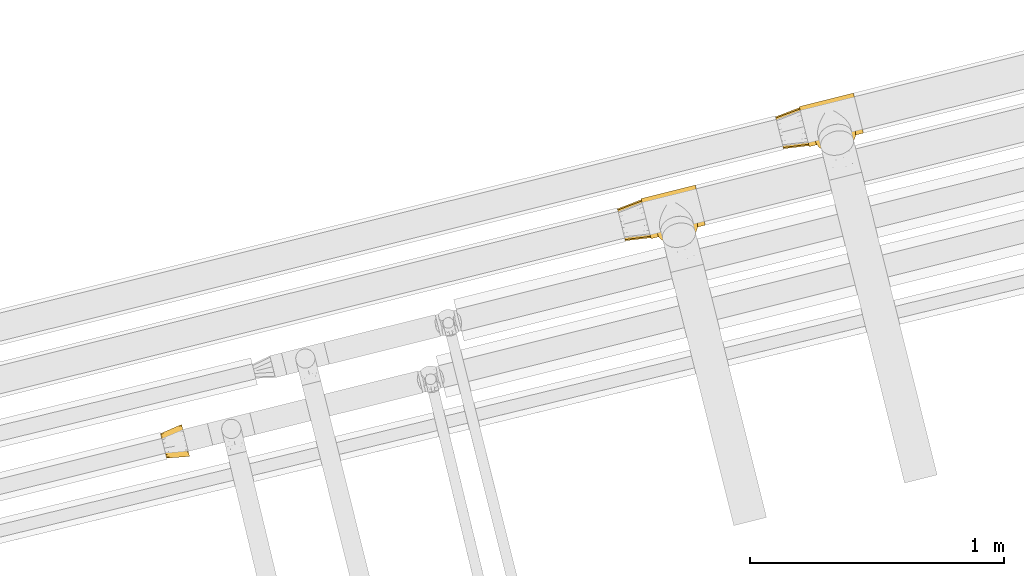
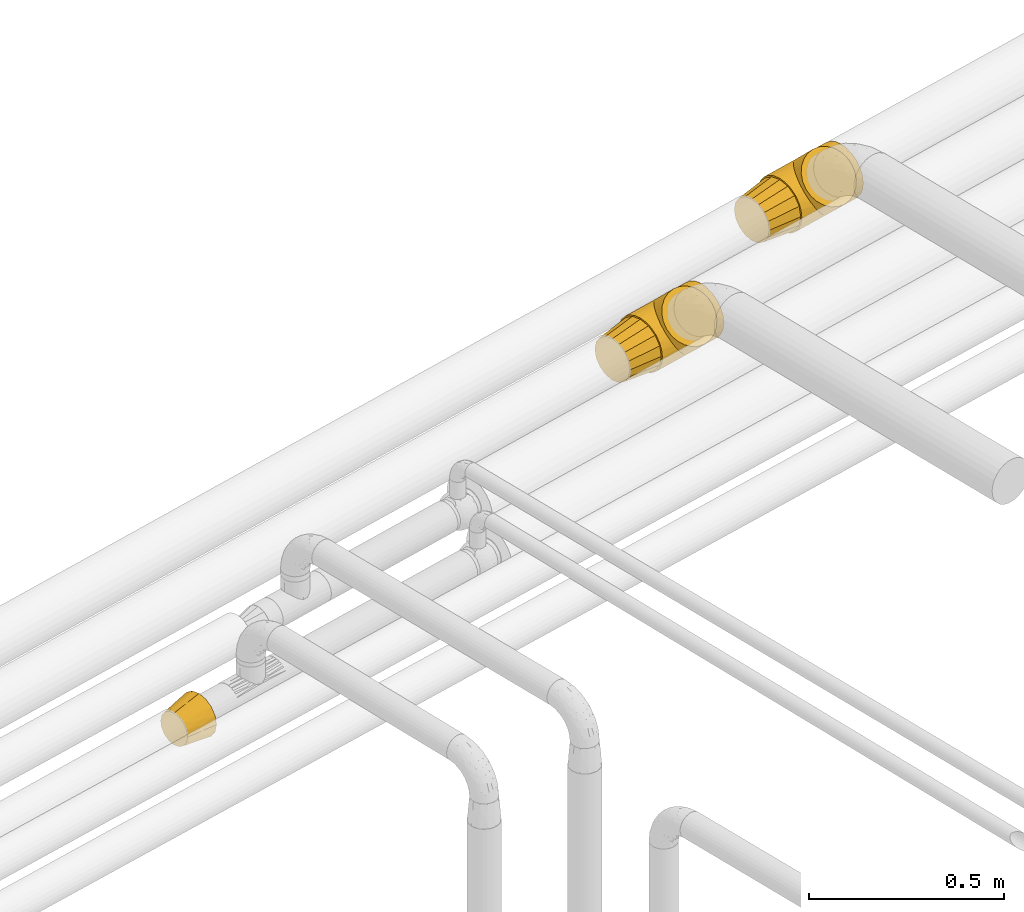
# One storey, part 12 of 93: 5 coverings.
"""IFC2X3 building model written with IfcOpenShell, lengths in millimetres."""

from ifc_helpers import new_model, entity, si_unit, converted_unit, derived_unit, direction, frame, origin, place, context, subcontext, project, spatial, faceted_brep, element, save


model = new_model("IFC2X3")

# Units and contexts
model_context = context("Model", 3, precision=0.01, world=origin(), true_north=direction((6.12303176911189e-17, 1.0)))
body_context = subcontext(model_context, "Body", "Model", "MODEL_VIEW")
ifc_project = project(units=[si_unit("LENGTHUNIT", "METRE", prefix="MILLI"), si_unit("AREAUNIT", "SQUARE_METRE"), si_unit("VOLUMEUNIT", "CUBIC_METRE"), converted_unit("PLANEANGLEUNIT", "DEGREE", entity("IfcRatioMeasure", 0.0174532925199433), si_unit("PLANEANGLEUNIT", "RADIAN"), dimensions=[0, 0, 0, 0, 0, 0, 0]), si_unit("MASSUNIT", "GRAM", prefix="KILO"), derived_unit("MASSDENSITYUNIT", [(si_unit("MASSUNIT", "GRAM", prefix="KILO"), 1), (si_unit("LENGTHUNIT", "METRE"), -3)]), derived_unit("MOMENTOFINERTIAUNIT", [(si_unit("LENGTHUNIT", "METRE"), 4)]), si_unit("TIMEUNIT", "SECOND"), si_unit("FREQUENCYUNIT", "HERTZ"), si_unit("THERMODYNAMICTEMPERATUREUNIT", "DEGREE_CELSIUS"), derived_unit("THERMALTRANSMITTANCEUNIT", [(si_unit("MASSUNIT", "GRAM", prefix="KILO"), 1), (si_unit("THERMODYNAMICTEMPERATUREUNIT", "KELVIN"), -1), (si_unit("TIMEUNIT", "SECOND"), -3)]), derived_unit("VOLUMETRICFLOWRATEUNIT", [(si_unit("LENGTHUNIT", "METRE"), 3), (si_unit("TIMEUNIT", "SECOND"), -1)]), derived_unit("MASSFLOWRATEUNIT", [(si_unit("MASSUNIT", "GRAM", prefix="KILO"), 1), (si_unit("TIMEUNIT", "SECOND"), -1)]), derived_unit("ROTATIONALFREQUENCYUNIT", [(si_unit("TIMEUNIT", "SECOND"), -1)]), si_unit("ELECTRICCURRENTUNIT", "AMPERE"), si_unit("ELECTRICVOLTAGEUNIT", "VOLT"), si_unit("POWERUNIT", "WATT"), si_unit("FORCEUNIT", "NEWTON", prefix="KILO"), si_unit("ILLUMINANCEUNIT", "LUX"), si_unit("LUMINOUSFLUXUNIT", "LUMEN"), si_unit("LUMINOUSINTENSITYUNIT", "CANDELA"), derived_unit("USERDEFINED", [(si_unit("MASSUNIT", "GRAM", prefix="KILO"), -1), (si_unit("LENGTHUNIT", "METRE"), -2), (si_unit("TIMEUNIT", "SECOND"), 3), (si_unit("LUMINOUSFLUXUNIT", "LUMEN"), 1)]), derived_unit("LINEARVELOCITYUNIT", [(si_unit("LENGTHUNIT", "METRE"), 1), (si_unit("TIMEUNIT", "SECOND"), -1)]), si_unit("PRESSUREUNIT", "PASCAL"), derived_unit("USERDEFINED", [(si_unit("LENGTHUNIT", "METRE"), -2), (si_unit("MASSUNIT", "GRAM", prefix="KILO"), 1), (si_unit("TIMEUNIT", "SECOND"), -2)]), derived_unit("LINEARFORCEUNIT", [(si_unit("MASSUNIT", "GRAM", prefix="KILO"), 1), (si_unit("LENGTHUNIT", "METRE"), 1), (si_unit("TIMEUNIT", "SECOND"), -2), (si_unit("LENGTHUNIT", "METRE"), -1)]), derived_unit("PLANARFORCEUNIT", [(si_unit("MASSUNIT", "GRAM", prefix="KILO"), 1), (si_unit("LENGTHUNIT", "METRE"), 1), (si_unit("TIMEUNIT", "SECOND"), -2), (si_unit("LENGTHUNIT", "METRE"), -2)])], contexts=[model_context])

# Site, building, storey
site_placement = place(None, origin())
site = spatial("IfcSite", under=ifc_project, at=site_placement, CompositionType="ELEMENT")
building_placement = place(site_placement, origin())
building = spatial("IfcBuilding", under=site, at=building_placement, CompositionType="ELEMENT")
storey_placement = place(building_placement, frame((0.0, 0.0, -4200.0)))
storey = spatial("IfcBuildingStorey", under=building, at=storey_placement, CompositionType="ELEMENT", Elevation=-4200.0)

# Coverings
covering_1_placement = place(storey_placement, frame((-10016.88, 13066.73, 2416.82)))
element("IfcCovering", 1, at=covering_1_placement, inside=storey, Name=":ADSK_", ObjectType=":ADSK_", PredefinedType="INSULATION", context=body_context, shape_type="Brep", body=[
    faceted_brep([(155.75, 65.19, 34.74), (248.72, 96.58, 25.47), (251.85, 84.02, 42.35), (253.82, 76.12, 62.0), (181.65, 59.73, 56.86), (193.35, 59.34, 69.57), (254.49, 73.42, 83.1), (141.99, 69.97, 25.47), (132.08, 59.28, 34.74), (35.25, 43.36, 25.47), (169.03, 61.73, 45.23), (212.5, 64.32, 97.75), (253.82, 76.12, 104.19), (218.82, 70.26, 112.69), (252.84, 80.07, 114.02), (251.85, 84.02, 123.85), (248.72, 96.58, 140.72), (221.07, 89.69, 140.72), (221.49, 84.24, 134.06), (35.25, 43.36, 140.72), (65.09, 45.24, 134.06), (62.91, 50.26, 140.72), (250.29, 90.3, 132.28), (203.79, 60.78, 83.26), (221.92, 78.79, 127.39), (220.37, 74.53, 120.04), (215.66, 67.29, 105.22), (246.68, 104.77, 147.2), (218.58, 95.94, 146.12), (216.09, 102.2, 151.51), (244.64, 112.96, 153.68), (207.61, 115.22, 159.03), (242.26, 122.5, 157.75), (239.88, 132.03, 161.82), (211.85, 108.71, 155.27), (234.78, 152.5, 164.6), (184.12, 139.7, 164.6), (196.66, 127.89, 163.27), (202.13, 121.56, 161.15), (62.17, 56.95, 146.12), (170.64, 150.45, 163.47), (229.67, 172.97, 161.82), (156.64, 160.06, 160.26), (224.92, 192.04, 153.68), (128.18, 175.76, 148.7), (220.84, 208.42, 140.72), (142.42, 168.5, 155.26), (114.1, 181.81, 140.72), (104.51, 169.86, 148.7), (7.37, 155.2, 140.72), (2.27, 175.66, 62.0), (4.24, 167.76, 42.35), (7.37, 155.2, 25.47), (11.45, 138.82, 12.51), (16.21, 119.75, 4.37), (21.31, 99.28, 1.6), (26.41, 78.81, 4.37), (31.17, 59.74, 12.51), (38.39, 30.79, 42.35), (40.36, 22.89, 62.0), (41.03, 20.2, 83.1), (40.36, 22.89, 104.19), (39.37, 26.84, 114.02), (38.39, 30.79, 123.85), (36.82, 37.08, 132.28), (33.21, 51.55, 147.2), (31.17, 59.74, 153.68), (28.79, 69.28, 157.75), (26.41, 78.81, 161.82), (21.31, 99.28, 164.6), (16.21, 119.75, 161.82), (11.45, 138.82, 153.68), (4.24, 167.76, 123.85), (2.27, 175.66, 104.19), (1.6, 178.36, 83.1), (244.64, 112.96, 12.51), (239.88, 132.03, 4.37), (234.78, 152.5, 1.6), (229.67, 172.97, 4.37), (224.92, 192.04, 12.51), (220.84, 208.42, 25.47), (217.7, 220.99, 42.35), (215.73, 228.89, 62.0), (215.06, 231.58, 83.1), (215.73, 228.89, 104.19), (217.7, 220.99, 123.85), (121.97, 50.0, 45.23), (111.77, 42.31, 56.86), (101.63, 36.47, 69.57), (91.73, 32.84, 83.26), (82.38, 31.88, 97.75), (74.01, 34.16, 112.69), (70.64, 37.19, 120.04), (67.27, 40.23, 127.39), (78.19, 33.02, 105.22), (61.43, 63.64, 151.51), (62.11, 71.38, 155.27), (62.8, 79.12, 159.03), (66.53, 95.44, 163.27), (64.66, 87.28, 161.15), (72.05, 111.76, 164.6), (86.76, 142.63, 160.26), (95.35, 156.77, 155.26), (78.91, 127.58, 163.47), (219.75, 49.83, 121.46), (222.02, 57.55, 128.41), (224.29, 65.28, 135.35), (224.06, 69.07, 139.08), (223.83, 72.85, 142.81), (223.37, 80.43, 150.27), (220.22, 87.33, 157.73), (218.65, 90.78, 161.46), (217.07, 94.23, 165.19), (211.44, 99.99, 172.14), (205.81, 105.74, 179.09), (198.08, 109.97, 185.05), (190.35, 114.19, 191.02), (171.76, 118.99, 200.18), (151.3, 119.83, 205.94), (130.35, 116.63, 207.9), (110.36, 109.62, 205.94), (92.68, 99.28, 200.18), (78.52, 86.31, 191.02), (73.68, 78.95, 185.05), (68.84, 71.59, 179.09), (66.57, 63.87, 172.14), (64.3, 56.14, 165.19), (64.53, 52.35, 161.46), (64.76, 48.57, 157.73), (65.22, 40.99, 150.27), (68.37, 34.09, 142.81), (69.94, 30.64, 139.08), (71.52, 27.19, 135.35), (77.15, 21.43, 128.41), (82.78, 15.68, 121.46), (90.51, 11.45, 115.49), (98.24, 7.23, 109.52), (116.83, 2.43, 100.36), (137.3, 1.6, 94.6), (158.24, 4.79, 92.64), (178.23, 11.8, 94.6), (195.91, 22.14, 100.36), (210.07, 35.11, 109.52), (214.91, 42.47, 115.49)], [[[0, 1, 2]], [[2, 3, 4]], [[5, 3, 6]], [[5, 4, 3]], [[0, 7, 1]], [[7, 8, 9]], [[4, 10, 2]], [[0, 2, 10]], [[11, 6, 12]], [[13, 12, 14, 15]], [[16, 17, 18]], [[19, 20, 21]], [[16, 18, 22]], [[11, 23, 6]], [[15, 24, 25, 13]], [[24, 22, 18]], [[24, 15, 22]], [[12, 13, 26, 11]], [[6, 23, 5]], [[16, 27, 28]], [[29, 27, 30]], [[31, 30, 32, 33]], [[30, 31, 34, 29]], [[27, 29, 28]], [[35, 36, 37]], [[33, 37, 38, 31]], [[16, 28, 17]], [[39, 19, 21]], [[37, 33, 35]], [[40, 35, 41]], [[42, 41, 43]], [[44, 43, 45]], [[42, 40, 41]], [[44, 46, 43]], [[47, 44, 45]], [[48, 47, 49]], [[42, 43, 46]], [[35, 40, 36]], [[50, 51, 52, 53, 54, 55, 56, 57, 9, 58, 59, 60, 61, 62, 63, 64, 19, 65, 66, 67, 68, 69, 70, 71, 49, 72, 73, 74]], [[1, 75, 76, 77, 78, 79, 80, 81, 82, 83, 84, 85, 45, 43, 41, 35, 33, 32, 30, 27, 16, 22, 15, 14, 12, 6, 3, 2]], [[78, 77, 55, 54]], [[52, 80, 79, 53]], [[53, 79, 78, 54]], [[56, 76, 75, 57]], [[1, 7, 9, 57, 75]], [[55, 77, 76, 56]], [[86, 87, 58]], [[8, 86, 58]], [[9, 8, 58]], [[59, 88, 60]], [[59, 58, 87]], [[88, 59, 87]], [[89, 90, 60]], [[91, 63, 62, 61]], [[63, 91, 92, 93]], [[64, 93, 20]], [[61, 90, 94, 91]], [[60, 90, 61]], [[93, 64, 63]], [[20, 19, 64]], [[89, 60, 88]], [[66, 95, 96, 97]], [[95, 66, 65]], [[68, 98, 69]], [[19, 39, 65]], [[97, 68, 67, 66]], [[68, 97, 99, 98]], [[95, 65, 39]], [[98, 100, 69]], [[101, 102, 71]], [[102, 48, 71]], [[69, 103, 70]], [[103, 69, 100]], [[101, 70, 103]], [[101, 71, 70]], [[48, 49, 71]], [[47, 45, 85, 72, 49]], [[72, 85, 84, 73]], [[84, 83, 74, 73]], [[74, 83, 82, 50]], [[50, 82, 81, 51]], [[51, 81, 80, 52]], [[104, 105, 106, 107, 108, 109, 110, 111, 112, 113, 114, 115, 116, 117, 118, 119, 120, 121, 122, 123, 124, 125, 126, 127, 128, 129, 130, 131, 132, 133, 134, 135, 136, 137, 138, 139, 140, 141, 142, 143]], [[109, 108, 18]], [[24, 108, 107, 106]], [[105, 25, 106]], [[108, 24, 18]], [[13, 105, 104]], [[25, 105, 13]], [[25, 24, 106]], [[11, 104, 143]], [[23, 11, 143]], [[13, 104, 11, 26]], [[109, 18, 17]], [[143, 142, 23]], [[5, 142, 141]], [[4, 141, 140]], [[0, 140, 139]], [[4, 5, 141]], [[0, 10, 140]], [[7, 0, 139]], [[4, 140, 10]], [[142, 5, 23]], [[8, 139, 138]], [[138, 137, 87]], [[88, 137, 136]], [[88, 87, 137]], [[129, 20, 130]], [[8, 7, 139]], [[93, 132, 131, 130]], [[87, 86, 138]], [[8, 138, 86]], [[134, 91, 94, 90]], [[90, 135, 134]], [[133, 132, 92]], [[129, 21, 20]], [[89, 136, 135]], [[89, 135, 90]], [[91, 133, 92]], [[93, 130, 20]], [[91, 134, 133]], [[132, 93, 92]], [[136, 89, 88]], [[129, 128, 39]], [[95, 128, 127, 126]], [[97, 125, 124]], [[96, 125, 97]], [[96, 95, 126]], [[98, 124, 123]], [[100, 98, 123]], [[97, 124, 98, 99]], [[129, 39, 21]], [[123, 122, 100]], [[103, 122, 121]], [[101, 121, 120]], [[48, 120, 119]], [[101, 103, 121]], [[48, 102, 120]], [[47, 48, 119]], [[128, 95, 39]], [[101, 120, 102]], [[125, 96, 126]], [[122, 103, 100]], [[44, 119, 118]], [[118, 117, 42]], [[40, 117, 116]], [[40, 42, 117]], [[109, 28, 110]], [[44, 47, 119]], [[29, 112, 111, 110]], [[42, 46, 118]], [[44, 118, 46]], [[114, 31, 38, 37]], [[37, 115, 114]], [[113, 112, 34]], [[109, 17, 28]], [[36, 116, 115]], [[36, 115, 37]], [[31, 113, 34]], [[29, 110, 28]], [[31, 114, 113]], [[112, 29, 34]], [[116, 36, 40]]]),
])
covering_2_placement = place(storey_placement, frame((-10109.92, 13077.15, 2420.82)))
element("IfcCovering", 2, at=covering_2_placement, inside=storey, Name=":ADSK_", ObjectType=":ADSK_", PredefinedType="INSULATION", context=body_context, shape_type="Brep", body=[
    faceted_brep([(11.3, 88.8, 139.15), (8.75, 99.03, 132.1), (6.2, 109.26, 125.06), (4.5, 116.1, 114.51), (2.79, 122.93, 103.97), (2.19, 125.33, 91.53), (1.6, 127.73, 79.1), (2.19, 125.33, 66.66), (2.79, 122.93, 54.22), (4.5, 116.1, 43.68), (6.2, 109.26, 33.13), (8.75, 99.03, 26.09), (11.3, 88.8, 19.04), (14.31, 76.73, 16.57), (17.32, 64.66, 14.1), (20.33, 52.6, 16.57), (23.34, 40.53, 19.04), (25.89, 30.3, 26.09), (28.44, 20.07, 33.13), (30.14, 13.23, 43.68), (31.85, 6.4, 54.22), (32.45, 4.0, 66.66), (33.05, 1.6, 79.1), (32.45, 4.0, 91.53), (31.85, 6.4, 103.97), (30.14, 13.23, 114.51), (28.44, 20.07, 125.06), (25.89, 30.3, 132.1), (23.34, 40.53, 139.15), (20.33, 52.6, 141.62), (17.32, 64.66, 144.1), (14.31, 76.73, 141.62), (133.1, 13.66, 79.1), (132.17, 17.38, 59.82), (131.67, 19.38, 49.44), (129.64, 27.53, 36.87), (127.61, 35.68, 24.29), (124.57, 47.88, 15.89), (121.52, 60.08, 7.49), (117.94, 74.47, 4.54), (114.35, 88.86, 1.6), (109.69, 107.56, 5.43), (107.17, 117.63, 7.49), (104.13, 129.83, 15.89), (101.09, 142.03, 24.29), (99.06, 150.18, 36.87), (97.03, 158.33, 49.44), (96.31, 161.19, 64.27), (95.6, 164.05, 79.1), (96.53, 160.33, 98.37), (97.03, 158.33, 108.75), (99.06, 150.18, 121.32), (101.09, 142.03, 133.9), (104.13, 129.83, 142.3), (107.17, 117.63, 150.7), (110.76, 103.25, 153.65), (114.35, 88.86, 156.6), (119.01, 70.15, 152.76), (121.52, 60.08, 150.7), (124.57, 47.88, 142.3), (127.61, 35.68, 133.9), (129.64, 27.53, 121.32), (131.67, 19.38, 108.75), (132.39, 16.52, 93.92)], [[[0, 1, 2, 3, 4, 5, 6, 7, 8, 9, 10, 11, 12, 13, 14, 15, 16, 17, 18, 19, 20, 21, 22, 23, 24, 25, 26, 27, 28, 29, 30, 31]], [[32, 33, 34, 35, 36, 37, 38, 39, 40, 41, 42, 43, 44, 45, 46, 47, 48, 49, 50, 51, 52, 53, 54, 55, 56, 57, 58, 59, 60, 61, 62, 63]], [[28, 58, 57, 56, 30, 29]], [[59, 58, 28, 27, 26, 60]], [[26, 25, 24, 62, 61, 60]], [[22, 32, 63, 62, 24, 23]], [[4, 50, 49, 48, 6, 5]], [[51, 50, 4, 3, 2, 52]], [[2, 1, 0, 54, 53, 52]], [[30, 56, 55, 54, 0, 31]], [[12, 42, 41, 40, 14, 13]], [[43, 42, 12, 11, 10, 44]], [[10, 9, 8, 46, 45, 44]], [[6, 48, 47, 46, 8, 7]], [[20, 34, 33, 32, 22, 21]], [[35, 34, 20, 19, 18, 36]], [[18, 17, 16, 38, 37, 36]], [[14, 40, 39, 38, 16, 15]]]),
])
covering_3_placement = place(storey_placement, frame((-9394.07, 13429.15, 2416.9)))
element("IfcCovering", 3, at=covering_3_placement, inside=storey, Name=":ADSK_", ObjectType=":ADSK_", PredefinedType="INSULATION", context=body_context, shape_type="Brep", body=[
    faceted_brep([(155.75, 65.19, 34.74), (248.72, 96.58, 25.47), (251.85, 84.02, 42.35), (253.82, 76.12, 62.0), (181.65, 59.73, 56.86), (193.35, 59.34, 69.57), (254.49, 73.42, 83.1), (141.99, 69.97, 25.47), (132.08, 59.28, 34.74), (35.25, 43.36, 25.47), (169.03, 61.73, 45.23), (212.5, 64.32, 97.75), (253.82, 76.12, 104.19), (218.82, 70.26, 112.69), (252.84, 80.07, 114.02), (251.85, 84.02, 123.85), (248.72, 96.58, 140.72), (221.07, 89.69, 140.72), (221.49, 84.24, 134.06), (35.25, 43.36, 140.72), (65.09, 45.24, 134.06), (62.91, 50.26, 140.72), (250.29, 90.3, 132.28), (203.79, 60.78, 83.26), (221.92, 78.79, 127.39), (220.37, 74.53, 120.04), (215.66, 67.29, 105.22), (246.68, 104.77, 147.2), (218.58, 95.94, 146.12), (216.09, 102.2, 151.51), (244.64, 112.96, 153.68), (207.61, 115.22, 159.03), (242.26, 122.5, 157.75), (239.88, 132.03, 161.82), (211.85, 108.71, 155.27), (234.78, 152.5, 164.6), (184.12, 139.7, 164.6), (196.66, 127.89, 163.27), (202.13, 121.56, 161.15), (62.17, 56.95, 146.12), (170.64, 150.45, 163.47), (229.67, 172.97, 161.82), (156.64, 160.06, 160.26), (224.92, 192.04, 153.68), (128.18, 175.76, 148.7), (220.84, 208.42, 140.72), (142.42, 168.5, 155.26), (114.1, 181.81, 140.72), (104.51, 169.86, 148.7), (7.37, 155.2, 140.72), (2.27, 175.66, 62.0), (4.24, 167.76, 42.35), (7.37, 155.2, 25.47), (11.45, 138.82, 12.51), (16.21, 119.75, 4.37), (21.31, 99.28, 1.6), (26.41, 78.81, 4.37), (31.17, 59.74, 12.51), (38.39, 30.79, 42.35), (40.36, 22.89, 62.0), (41.03, 20.2, 83.1), (40.36, 22.89, 104.19), (39.37, 26.84, 114.02), (38.39, 30.79, 123.85), (36.82, 37.08, 132.28), (33.21, 51.55, 147.2), (31.17, 59.74, 153.68), (28.79, 69.28, 157.75), (26.41, 78.81, 161.82), (21.31, 99.28, 164.6), (16.21, 119.75, 161.82), (11.45, 138.82, 153.68), (4.24, 167.76, 123.85), (2.27, 175.66, 104.19), (1.6, 178.36, 83.1), (244.64, 112.96, 12.51), (239.88, 132.03, 4.37), (234.78, 152.5, 1.6), (229.67, 172.97, 4.37), (224.92, 192.04, 12.51), (220.84, 208.42, 25.47), (217.7, 220.99, 42.35), (215.73, 228.89, 62.0), (215.06, 231.58, 83.1), (215.73, 228.89, 104.19), (217.7, 220.99, 123.85), (121.97, 50.0, 45.23), (111.77, 42.31, 56.86), (101.63, 36.47, 69.57), (91.73, 32.84, 83.26), (82.38, 31.88, 97.75), (74.01, 34.16, 112.69), (70.64, 37.19, 120.04), (67.27, 40.23, 127.39), (78.19, 33.02, 105.22), (61.43, 63.64, 151.51), (62.11, 71.38, 155.27), (62.8, 79.12, 159.03), (66.53, 95.44, 163.27), (64.66, 87.28, 161.15), (72.05, 111.76, 164.6), (86.76, 142.63, 160.26), (95.35, 156.77, 155.26), (78.91, 127.58, 163.47), (219.75, 49.83, 121.46), (222.02, 57.55, 128.41), (224.29, 65.28, 135.35), (224.06, 69.07, 139.08), (223.83, 72.85, 142.81), (223.37, 80.43, 150.27), (220.22, 87.33, 157.73), (218.65, 90.78, 161.46), (217.07, 94.23, 165.19), (211.44, 99.99, 172.14), (205.81, 105.74, 179.09), (198.08, 109.97, 185.05), (190.35, 114.19, 191.02), (171.76, 118.99, 200.18), (151.3, 119.83, 205.94), (130.35, 116.63, 207.9), (110.36, 109.62, 205.94), (92.68, 99.28, 200.18), (78.52, 86.31, 191.02), (73.68, 78.95, 185.05), (68.84, 71.59, 179.09), (66.57, 63.87, 172.14), (64.3, 56.14, 165.19), (64.53, 52.35, 161.46), (64.76, 48.57, 157.73), (65.22, 40.99, 150.27), (68.37, 34.09, 142.81), (69.94, 30.64, 139.08), (71.52, 27.19, 135.35), (77.15, 21.43, 128.41), (82.78, 15.68, 121.46), (90.51, 11.45, 115.49), (98.24, 7.23, 109.52), (116.83, 2.43, 100.36), (137.3, 1.6, 94.6), (158.24, 4.79, 92.64), (178.23, 11.8, 94.6), (195.91, 22.14, 100.36), (210.07, 35.11, 109.52), (214.91, 42.47, 115.49)], [[[0, 1, 2]], [[2, 3, 4]], [[5, 3, 6]], [[5, 4, 3]], [[0, 7, 1]], [[7, 8, 9]], [[4, 10, 2]], [[0, 2, 10]], [[11, 6, 12]], [[13, 12, 14, 15]], [[16, 17, 18]], [[19, 20, 21]], [[16, 18, 22]], [[11, 23, 6]], [[15, 24, 25, 13]], [[24, 22, 18]], [[24, 15, 22]], [[12, 13, 26, 11]], [[6, 23, 5]], [[16, 27, 28]], [[29, 27, 30]], [[31, 30, 32, 33]], [[30, 31, 34, 29]], [[27, 29, 28]], [[35, 36, 37]], [[33, 37, 38, 31]], [[16, 28, 17]], [[39, 19, 21]], [[37, 33, 35]], [[40, 35, 41]], [[42, 41, 43]], [[44, 43, 45]], [[42, 40, 41]], [[44, 46, 43]], [[47, 44, 45]], [[48, 47, 49]], [[42, 43, 46]], [[35, 40, 36]], [[50, 51, 52, 53, 54, 55, 56, 57, 9, 58, 59, 60, 61, 62, 63, 64, 19, 65, 66, 67, 68, 69, 70, 71, 49, 72, 73, 74]], [[1, 75, 76, 77, 78, 79, 80, 81, 82, 83, 84, 85, 45, 43, 41, 35, 33, 32, 30, 27, 16, 22, 15, 14, 12, 6, 3, 2]], [[78, 77, 55, 54]], [[52, 80, 79, 53]], [[53, 79, 78, 54]], [[56, 76, 75, 57]], [[1, 7, 9, 57, 75]], [[55, 77, 76, 56]], [[86, 87, 58]], [[8, 86, 58]], [[9, 8, 58]], [[59, 88, 60]], [[59, 58, 87]], [[88, 59, 87]], [[89, 90, 60]], [[91, 63, 62, 61]], [[63, 91, 92, 93]], [[64, 93, 20]], [[61, 90, 94, 91]], [[60, 90, 61]], [[93, 64, 63]], [[20, 19, 64]], [[89, 60, 88]], [[66, 95, 96, 97]], [[95, 66, 65]], [[68, 98, 69]], [[19, 39, 65]], [[97, 68, 67, 66]], [[68, 97, 99, 98]], [[95, 65, 39]], [[98, 100, 69]], [[101, 102, 71]], [[102, 48, 71]], [[69, 103, 70]], [[103, 69, 100]], [[101, 70, 103]], [[101, 71, 70]], [[48, 49, 71]], [[47, 45, 85, 72, 49]], [[72, 85, 84, 73]], [[84, 83, 74, 73]], [[74, 83, 82, 50]], [[50, 82, 81, 51]], [[51, 81, 80, 52]], [[104, 105, 106, 107, 108, 109, 110, 111, 112, 113, 114, 115, 116, 117, 118, 119, 120, 121, 122, 123, 124, 125, 126, 127, 128, 129, 130, 131, 132, 133, 134, 135, 136, 137, 138, 139, 140, 141, 142, 143]], [[109, 108, 18]], [[24, 108, 107, 106]], [[105, 25, 106]], [[108, 24, 18]], [[13, 105, 104]], [[25, 105, 13]], [[25, 24, 106]], [[11, 104, 143]], [[23, 11, 143]], [[13, 104, 11, 26]], [[109, 18, 17]], [[143, 142, 23]], [[5, 142, 141]], [[4, 141, 140]], [[0, 140, 139]], [[4, 5, 141]], [[0, 10, 140]], [[7, 0, 139]], [[4, 140, 10]], [[142, 5, 23]], [[8, 139, 138]], [[138, 137, 87]], [[88, 137, 136]], [[88, 87, 137]], [[129, 20, 130]], [[8, 7, 139]], [[93, 132, 131, 130]], [[87, 86, 138]], [[8, 138, 86]], [[134, 91, 94, 90]], [[90, 135, 134]], [[133, 132, 92]], [[129, 21, 20]], [[89, 136, 135]], [[89, 135, 90]], [[91, 133, 92]], [[93, 130, 20]], [[91, 134, 133]], [[132, 93, 92]], [[136, 89, 88]], [[129, 128, 39]], [[95, 128, 127, 126]], [[97, 125, 124]], [[96, 125, 97]], [[96, 95, 126]], [[98, 124, 123]], [[100, 98, 123]], [[97, 124, 98, 99]], [[129, 39, 21]], [[123, 122, 100]], [[103, 122, 121]], [[101, 121, 120]], [[48, 120, 119]], [[101, 103, 121]], [[48, 102, 120]], [[47, 48, 119]], [[128, 95, 39]], [[101, 120, 102]], [[125, 96, 126]], [[122, 103, 100]], [[44, 119, 118]], [[118, 117, 42]], [[40, 117, 116]], [[40, 42, 117]], [[109, 28, 110]], [[44, 47, 119]], [[29, 112, 111, 110]], [[42, 46, 118]], [[44, 118, 46]], [[114, 31, 38, 37]], [[37, 115, 114]], [[113, 112, 34]], [[109, 17, 28]], [[36, 116, 115]], [[36, 115, 37]], [[31, 113, 34]], [[29, 110, 28]], [[31, 114, 113]], [[112, 29, 34]], [[116, 36, 40]]]),
])
covering_4_placement = place(storey_placement, frame((-9487.1, 13439.58, 2420.9)))
element("IfcCovering", 4, at=covering_4_placement, inside=storey, Name=":ADSK_", ObjectType=":ADSK_", PredefinedType="INSULATION", context=body_context, shape_type="Brep", body=[
    faceted_brep([(127.61, 35.68, 24.29), (124.57, 47.88, 15.89), (121.52, 60.08, 7.49), (119.01, 70.15, 5.43), (114.35, 88.86, 1.6), (109.69, 107.56, 5.43), (107.17, 117.63, 7.49), (104.13, 129.83, 15.89), (101.09, 142.03, 24.29), (99.06, 150.18, 36.87), (97.03, 158.33, 49.44), (96.53, 160.33, 59.82), (95.6, 164.05, 79.1), (96.53, 160.33, 98.37), (97.03, 158.33, 108.75), (99.06, 150.18, 121.32), (101.09, 142.03, 133.9), (104.13, 129.83, 142.3), (107.17, 117.63, 150.7), (109.69, 107.56, 152.76), (114.35, 88.86, 156.6), (119.01, 70.15, 152.76), (121.52, 60.08, 150.7), (124.57, 47.88, 142.3), (127.61, 35.68, 133.9), (129.64, 27.53, 121.32), (131.67, 19.38, 108.75), (132.17, 17.38, 98.37), (133.1, 13.66, 79.1), (132.17, 17.38, 59.82), (131.67, 19.38, 49.44), (129.64, 27.53, 36.87), (1.6, 127.73, 79.1), (2.19, 125.33, 66.66), (2.79, 122.93, 54.22), (4.5, 116.1, 43.68), (6.2, 109.26, 33.13), (8.75, 99.03, 26.09), (11.3, 88.8, 19.04), (14.31, 76.73, 16.57), (17.32, 64.66, 14.1), (20.33, 52.6, 16.57), (23.34, 40.53, 19.04), (25.89, 30.3, 26.09), (28.44, 20.07, 33.13), (30.14, 13.23, 43.68), (31.85, 6.4, 54.22), (32.45, 4.0, 66.66), (33.05, 1.6, 79.1), (32.45, 4.0, 91.53), (31.85, 6.4, 103.97), (30.14, 13.23, 114.51), (28.44, 20.07, 125.06), (25.89, 30.3, 132.1), (23.34, 40.53, 139.15), (20.33, 52.6, 141.62), (17.32, 64.66, 144.1), (14.31, 76.73, 141.62), (11.3, 88.8, 139.15), (8.75, 99.03, 132.1), (6.2, 109.26, 125.06), (4.5, 116.1, 114.51), (2.79, 122.93, 103.97), (2.19, 125.33, 91.53)], [[[0, 1, 2, 3, 4, 5, 6, 7, 8, 9, 10, 11, 12, 13, 14, 15, 16, 17, 18, 19, 20, 21, 22, 23, 24, 25, 26, 27, 28, 29, 30, 31]], [[32, 33, 34, 35, 36, 37, 38, 39, 40, 41, 42, 43, 44, 45, 46, 47, 48, 49, 50, 51, 52, 53, 54, 55, 56, 57, 58, 59, 60, 61, 62, 63]], [[31, 30, 46, 45, 44, 0]], [[42, 2, 1, 0, 44, 43]], [[46, 30, 29, 28, 48, 47]], [[41, 40, 4, 3, 2, 42]], [[7, 6, 38, 37, 36, 8]], [[34, 10, 9, 8, 36, 35]], [[38, 6, 5, 4, 40, 39]], [[33, 32, 12, 11, 10, 34]], [[15, 14, 62, 61, 60, 16]], [[58, 18, 17, 16, 60, 59]], [[62, 14, 13, 12, 32, 63]], [[57, 56, 20, 19, 18, 58]], [[23, 22, 54, 53, 52, 24]], [[50, 26, 25, 24, 52, 51]], [[54, 22, 21, 20, 56, 55]], [[49, 48, 28, 27, 26, 50]]]),
])
covering_5_placement = place(storey_placement, frame((-11908.73, 12221.27, 2436.68)))
element("IfcCovering", 5, at=covering_5_placement, inside=storey, Name=":ADSK_", ObjectType=":ADSK_", PredefinedType="INSULATION", context=body_context, shape_type="Brep", body=[
    faceted_brep([(94.03, 95.78, 126.65), (97.08, 83.54, 129.16), (100.05, 71.65, 131.6), (103.06, 59.58, 129.12), (106.07, 47.51, 126.65), (108.62, 37.28, 119.6), (111.17, 27.05, 112.56), (112.87, 20.22, 102.01), (114.58, 13.38, 91.47), (115.18, 10.95, 78.85), (115.77, 8.58, 66.6), (115.18, 10.98, 54.16), (114.58, 13.38, 41.72), (112.87, 20.22, 31.18), (111.17, 27.05, 20.63), (108.62, 37.28, 13.59), (106.07, 47.51, 6.54), (103.06, 59.58, 4.07), (100.05, 71.65, 1.6), (97.04, 83.72, 4.07), (94.03, 95.78, 6.54), (91.48, 106.01, 13.59), (88.93, 116.25, 20.63), (87.22, 123.08, 31.18), (85.52, 129.92, 41.72), (84.92, 132.32, 54.16), (84.32, 134.72, 66.6), (84.92, 132.32, 79.03), (85.52, 129.92, 91.47), (87.22, 123.08, 102.01), (88.93, 116.25, 112.56), (91.48, 106.01, 119.6), (5.14, 84.41, 98.68), (3.83, 89.67, 90.57), (2.52, 94.93, 82.46), (2.06, 96.78, 72.89), (1.6, 98.62, 63.32), (2.05, 96.8, 53.85), (2.52, 94.93, 44.19), (3.83, 89.67, 36.08), (5.14, 84.41, 27.97), (7.1, 76.54, 22.55), (9.06, 68.68, 17.13), (11.4, 59.3, 15.21), (13.69, 50.11, 13.32), (15.98, 40.92, 15.21), (18.32, 31.54, 17.13), (20.28, 23.67, 22.55), (22.25, 15.8, 27.97), (23.56, 10.55, 36.08), (24.87, 5.29, 44.19), (25.33, 3.42, 53.85), (25.79, 1.6, 63.32), (25.33, 3.44, 72.89), (24.87, 5.29, 82.46), (23.56, 10.55, 90.57), (22.25, 15.8, 98.68), (20.28, 23.67, 104.1), (18.32, 31.54, 109.52), (16.01, 40.83, 111.42), (13.69, 50.11, 113.32), (11.38, 59.39, 111.42), (9.06, 68.68, 109.52), (7.1, 76.55, 104.1), (70.88, 5.1, 64.96), (70.18, 7.49, 48.27), (68.84, 12.89, 35.64), (67.19, 19.51, 26.38), (60.91, 44.68, 9.94), (63.96, 32.43, 15.5), (56.96, 60.9, 7.45), (52.83, 77.07, 9.94), (49.78, 89.33, 15.5), (47.54, 98.31, 22.32), (43.56, 114.27, 48.27), (44.9, 108.87, 35.64), (43.05, 116.71, 64.96), (44.6, 110.08, 92.06), (43.39, 114.93, 79.2), (56.96, 60.9, 122.48), (46.25, 103.48, 102.09), (52.83, 77.07, 119.98), (49.78, 89.33, 114.42), (63.43, 34.58, 115.67), (60.32, 47.06, 120.67), (65.85, 24.85, 108.86), (70.18, 7.49, 81.65), (68.84, 12.89, 94.28)], [[[0, 1, 2, 3, 4, 5, 6, 7, 8, 9, 10, 11, 12, 13, 14, 15, 16, 17, 18, 19, 20, 21, 22, 23, 24, 25, 26, 27, 28, 29, 30, 31]], [[32, 33, 34, 35, 36, 37, 38, 39, 40, 41, 42, 43, 44, 45, 46, 47, 48, 49, 50, 51, 52, 53, 54, 55, 56, 57, 58, 59, 60, 61, 62, 63]], [[64, 51, 65]], [[51, 64, 52]], [[10, 64, 11]], [[65, 12, 11]], [[65, 11, 64]], [[12, 65, 66]], [[14, 13, 67]], [[51, 50, 65]], [[46, 45, 68]], [[68, 17, 16]], [[68, 69, 46]], [[16, 69, 68]], [[66, 50, 49]], [[67, 69, 15]], [[67, 13, 66]], [[67, 49, 48]], [[13, 12, 66]], [[66, 65, 50]], [[18, 17, 70]], [[45, 44, 70]], [[70, 17, 68]], [[70, 68, 45]], [[69, 16, 15]], [[67, 47, 69]], [[49, 67, 66]], [[67, 15, 14]], [[47, 46, 69]], [[67, 48, 47]], [[70, 43, 71]], [[43, 70, 44]], [[18, 70, 19]], [[71, 20, 19]], [[71, 19, 70]], [[20, 71, 72]], [[22, 21, 73]], [[43, 42, 71]], [[38, 37, 74]], [[74, 25, 24]], [[74, 75, 38]], [[24, 75, 74]], [[72, 42, 41]], [[73, 75, 23]], [[73, 21, 72]], [[73, 41, 40]], [[21, 20, 72]], [[72, 71, 42]], [[26, 25, 76]], [[37, 36, 76]], [[76, 25, 74]], [[76, 74, 37]], [[75, 24, 23]], [[73, 39, 75]], [[41, 73, 72]], [[73, 23, 22]], [[39, 38, 75]], [[73, 40, 39]], [[34, 33, 77]], [[77, 28, 78]], [[76, 35, 78]], [[60, 79, 61]], [[79, 2, 1]], [[78, 34, 77]], [[33, 80, 77]], [[29, 77, 80]], [[35, 34, 78]], [[79, 1, 81]], [[62, 61, 81]], [[81, 82, 62]], [[79, 81, 61]], [[78, 28, 27]], [[29, 28, 77]], [[27, 76, 78]], [[82, 32, 63, 62]], [[80, 33, 32]], [[82, 81, 0]], [[1, 0, 81]], [[82, 0, 31, 30]], [[82, 30, 80]], [[82, 80, 32]], [[29, 80, 30]], [[76, 27, 26]], [[36, 35, 76]], [[58, 57, 83]], [[83, 4, 84]], [[79, 59, 84]], [[52, 64, 53]], [[64, 10, 9]], [[84, 58, 83]], [[57, 85, 83]], [[5, 83, 85]], [[59, 58, 84]], [[64, 9, 86]], [[54, 53, 86]], [[86, 87, 54]], [[64, 86, 53]], [[84, 4, 3]], [[5, 4, 83]], [[3, 79, 84]], [[87, 56, 55, 54]], [[85, 57, 56]], [[87, 86, 8]], [[9, 8, 86]], [[87, 8, 7, 6]], [[87, 6, 85]], [[87, 85, 56]], [[5, 85, 6]], [[79, 3, 2]], [[60, 59, 79]]]),
])

save(model, "model.ifc")
